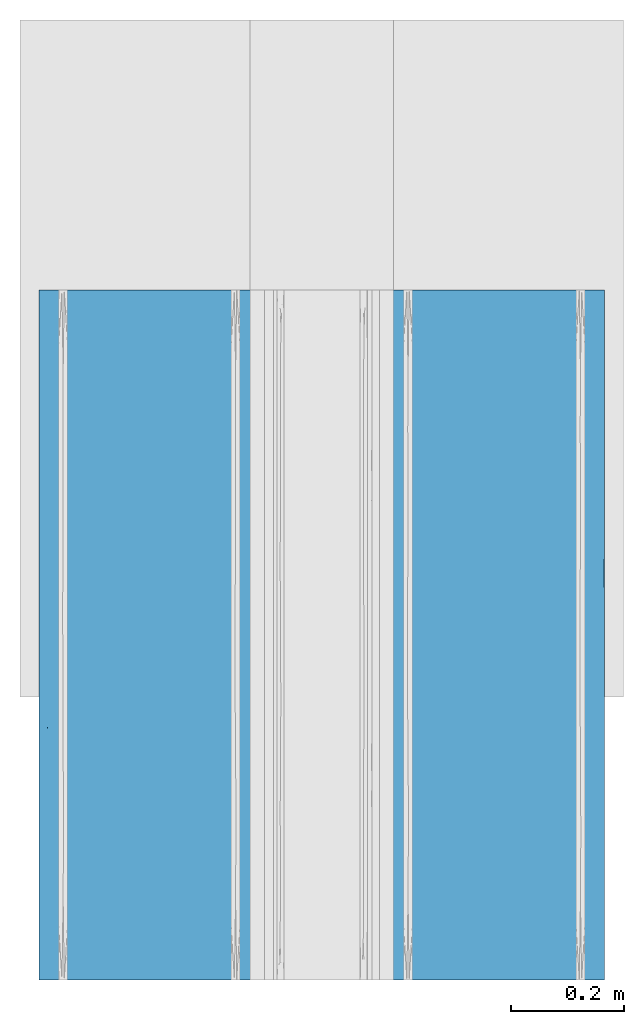
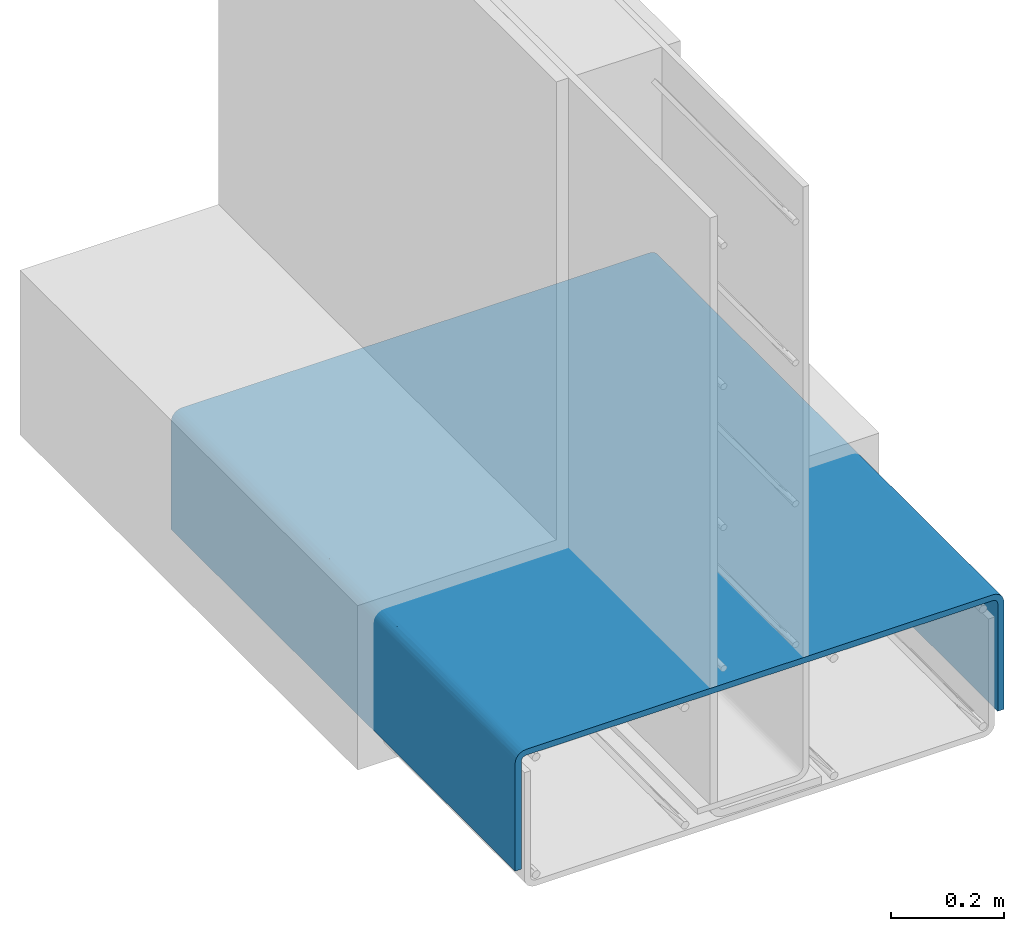
# One storey, part 3 of 10: 1 wall.
"""IFC2X3 building model written with IfcOpenShell, lengths in feet."""

from ifc_helpers import new_model, entity, si_unit, converted_unit, derived_unit, direction, frame, origin, place, context, subcontext, project, spatial, faceted_brep, material, type_object, element, save


model = new_model("IFC2X3")

# Units and contexts
model_context = context("Model", 3, precision=0.0001, world=origin(), true_north=direction((6.12303176911189e-17, 1.0)))
body_context = subcontext(model_context, "Body", "Model", "MODEL_VIEW")
ifc_project = project(units=[converted_unit("LENGTHUNIT", "FOOT", entity("IfcRatioMeasure", 0.3048), si_unit("LENGTHUNIT", "METRE"), dimensions=[1, 0, 0, 0, 0, 0, 0]), converted_unit("AREAUNIT", "SQUARE FOOT", entity("IfcRatioMeasure", 0.09290304), si_unit("AREAUNIT", "SQUARE_METRE"), dimensions=[2, 0, 0, 0, 0, 0, 0]), converted_unit("VOLUMEUNIT", "CUBIC FOOT", entity("IfcRatioMeasure", 0.028316846592), si_unit("VOLUMEUNIT", "CUBIC_METRE"), dimensions=[3, 0, 0, 0, 0, 0, 0]), converted_unit("PLANEANGLEUNIT", "DEGREE", entity("IfcRatioMeasure", 0.0174532925199433), si_unit("PLANEANGLEUNIT", "RADIAN"), dimensions=[0, 0, 0, 0, 0, 0, 0]), si_unit("MASSUNIT", "GRAM", prefix="KILO"), derived_unit("MASSDENSITYUNIT", [(si_unit("MASSUNIT", "GRAM", prefix="KILO"), 1), (si_unit("LENGTHUNIT", "METRE"), -3)]), si_unit("TIMEUNIT", "SECOND"), si_unit("FREQUENCYUNIT", "HERTZ"), si_unit("THERMODYNAMICTEMPERATUREUNIT", "DEGREE_CELSIUS"), derived_unit("THERMALTRANSMITTANCEUNIT", [(si_unit("MASSUNIT", "GRAM", prefix="KILO"), 1), (si_unit("THERMODYNAMICTEMPERATUREUNIT", "KELVIN"), -1), (si_unit("TIMEUNIT", "SECOND"), -3)]), derived_unit("VOLUMETRICFLOWRATEUNIT", [(si_unit("LENGTHUNIT", "METRE"), 3), (si_unit("TIMEUNIT", "SECOND"), -1)]), si_unit("ELECTRICCURRENTUNIT", "AMPERE"), si_unit("ELECTRICVOLTAGEUNIT", "VOLT"), si_unit("POWERUNIT", "WATT"), si_unit("FORCEUNIT", "NEWTON", prefix="KILO"), si_unit("ILLUMINANCEUNIT", "LUX"), si_unit("LUMINOUSFLUXUNIT", "LUMEN"), si_unit("LUMINOUSINTENSITYUNIT", "CANDELA"), derived_unit("USERDEFINED", [(si_unit("MASSUNIT", "GRAM", prefix="KILO"), -1), (si_unit("LENGTHUNIT", "METRE"), -2), (si_unit("TIMEUNIT", "SECOND"), 3), (si_unit("LUMINOUSFLUXUNIT", "LUMEN"), 1)]), derived_unit("LINEARVELOCITYUNIT", [(si_unit("LENGTHUNIT", "METRE"), 1), (si_unit("TIMEUNIT", "SECOND"), -1)]), si_unit("PRESSUREUNIT", "PASCAL"), derived_unit("USERDEFINED", [(si_unit("LENGTHUNIT", "METRE"), -2), (si_unit("MASSUNIT", "GRAM", prefix="KILO"), 1), (si_unit("TIMEUNIT", "SECOND"), -2)])], contexts=[model_context])

# Site, building, storey
site_placement = place(None, origin())
site = spatial("IfcSite", under=ifc_project, at=site_placement, CompositionType="ELEMENT")
building_placement = place(site_placement, origin())
building = spatial("IfcBuilding", under=site, at=building_placement, CompositionType="ELEMENT")
storey_placement = place(building_placement, frame((0.0, 0.0, 11.2604166666667)))
storey = spatial("IfcBuildingStorey", under=building, at=storey_placement, Name="2ND FLOOR", CompositionType="ELEMENT", Elevation=11.2604166666667)

# Wall
ifc_material = material()
wall_type = type_object("IfcWallType", Name="Generic Models 1", PredefinedType="NOTDEFINED", material=ifc_material)
wall_placement = place(storey_placement, frame((1428.03816369988, 0.24999999999582, 2.97795007741488), z_axis=(0.0, 0.0, 1.0), x_axis=(0.0, 1.0, 0.0)))
element("IfcWall", 1, at=wall_placement, inside=storey, type_object=wall_type, material=ifc_material, Name="Generic Models 46:Generic Models 1", ObjectType="Generic Models 46:Generic Models 1", context=body_context, shape_type="Brep", body=[
    faceted_brep([(4.0, 0.0, 0.0), (4.0, 0.0, 0.764315473946937), (4.0, -0.00252919618446867, 0.783526626268003), (4.0, -0.00994442419801089, 0.801428570306319), (4.0, -0.0217403485055456, 0.816801318160033), (4.0, -0.037113096359235, 0.828597242467586), (4.0, -0.0550150403976204, 0.8360124704811), (4.0, -0.0742261927186973, 0.838541666665574), (4.0, -3.20702380728176, 0.8385416666657), (4.0, -3.22623495960283, 0.8360124704811), (4.0, -3.24413690364122, 0.828597242467584), (4.0, -3.25950965149491, 0.816801318160033), (4.0, -3.27130557580244, 0.801428570306317), (4.0, -3.27872080381599, 0.783526626268003), (4.0, -3.28125000000045, 0.764315473946937), (4.0, -3.28125000000045, 0.0), (4.0, -3.23958333333371, 0.0), (4.0, -3.23958333333394, 0.764315473946937), (4.0, -3.2384738943872, 0.77274249938873), (4.0, -3.23522118397796, 0.780595236972985), (4.0, -3.23004686894546, 0.787338535610594), (4.0, -3.22330357030773, 0.792512850643233), (4.0, -3.21545083272349, 0.795765561052388), (4.0, -3.20702380728176, 0.796875000000808), (4.0, -0.0742261927186973, 0.796874999999034), (4.0, -0.065799167276964, 0.795765561052388), (4.0, -0.0579464296927199, 0.792512850643233), (4.0, -0.0512031310549901, 0.787338535610594), (4.0, -0.0460288160224991, 0.780595236972985), (4.0, -0.0427761056132567, 0.77274249938873), (4.0, -0.0416666666667425, 0.764315473946937), (4.0, -0.0416666666667425, 0.0), (0.0, -0.0550150403976204, 0.836012470481107), (0.0, -0.037113096359235, 0.828597242467593), (0.0, -0.0217403485055456, 0.81680131816004), (0.0, -0.00994442419801089, 0.801428570306326), (0.0, -0.00252919618446867, 0.78352662626801), (0.0, 0.0, 0.764315473946944), (0.0, 0.0, 0.0), (0.0, -0.0416666666667425, 0.0), (0.0, -0.0416666666665151, 0.764315473946944), (0.0, -0.0427761056132567, 0.772742499388738), (0.0, -0.0460288160224991, 0.780595236972992), (0.0, -0.0512031310549901, 0.787338535610601), (0.0, -0.0579464296927199, 0.79251285064324), (0.0, -0.065799167276964, 0.795765561052395), (0.0, -0.0742261927186973, 0.796874999999041), (0.0, -3.20702380728176, 0.796874999999041), (0.0, -3.21545083272349, 0.795765561052395), (0.0, -3.22330357030773, 0.79251285064324), (0.0, -3.23004686894546, 0.787338535610601), (0.0, -3.23522118397796, 0.780595236972992), (0.0, -3.2384738943872, 0.772742499388738), (0.0, -3.23958333333394, 0.764315473946944), (0.0, -3.23958333333371, 0.0), (0.0, -3.28125000000045, 0.0), (0.0, -3.28125000000045, 0.764315473946944), (0.0, -3.27872080381599, 0.78352662626801), (0.0, -3.27130557580244, 0.801428570306324), (0.0, -3.25950965149491, 0.81680131816004), (0.0, -3.24413690364122, 0.828597242467591), (0.0, -3.22623495960283, 0.836012470481107), (0.0, -3.20702380728176, 0.838541666665707), (0.0, -0.0742261927186973, 0.838541666665707), (0.180442580674759, -0.0742261927186973, 0.796874999999041), (0.360885161349518, -0.0742261927186973, 0.796874999999041), (0.639114829065253, -0.0742261927186973, 0.796874999999041), (0.958672224427413, -0.0742261927186973, 0.796874999999039), (1.2782296581305, -0.0742261927186973, 0.796874999999037), (1.5977870918336, -0.0742261927186973, 0.796874999999037), (1.75756578951468, -0.0742261927186973, 0.796874999999037), (1.91734448719576, -0.0742261927186973, 0.796874999999037), (2.23690188255792, -0.0742261927189247, 0.796874999999037), (2.55645931626101, -0.0742261927186973, 0.796874999999037), (2.73690189693576, -0.0742261927186973, 0.796874999999037), (2.91734451595145, -0.0742261927186973, 0.796874999999037), (3.09778709662621, -0.0742261927186973, 0.796874999999035), (3.27822967730097, -0.0742261927186973, 0.796874999999035), (3.45867225797573, -0.0742261927186973, 0.796874999999034), (3.63911483865049, -0.0742261927186973, 0.796874999999034), (3.81955741932524, -0.0742261927189247, 0.796874999999034), (3.81955740038469, -3.20702380728176, 0.796874999999034), (3.63911480076936, -3.20702380728176, 0.796874999999035), (3.36088523640947, -3.20702380728176, 0.796874999999034), (3.04132770589896, -3.20702380728176, 0.796874999999035), (2.72177032410369, -3.20702380728176, 0.796874999999035), (2.40221294230842, -3.20702380728176, 0.796874999999035), (2.24243417705317, -3.20702380728176, 0.796874999999037), (2.08265541179791, -3.20702380728176, 0.796874999999037), (1.76309803000264, -3.20702380728176, 0.796874999999039), (1.44354064820737, -3.20702380728198, 0.796874999999039), (1.26309804859205, -3.20702380728198, 0.796874999999041), (1.08265544897672, -3.20702380728198, 0.796874999999039), (0.902212849361396, -3.20702380728176, 0.796874999999039), (0.721770249746071, -3.20702380728176, 0.796874999999039), (0.541327650130745, -3.20702380728176, 0.796874999999039), (0.360885050515419, -3.20702380728176, 0.796874999999039), (0.180442599615337, -3.20702380728176, 0.796874999999041), (0.544897213082494, -3.20702380728176, 0.838541666665705), (1.08978317725471, -3.20702380728176, 0.838541666665705), (1.63466914142694, -3.20702380728176, 0.838541666665705), (2.17956635450942, -3.20702380728176, 0.838541666665703), (2.91022807165557, -3.20702380728176, 0.838541666665702), (3.45511403582779, -3.20702380728176, 0.8385416666657), (3.45510810898161, -0.0742261927186973, 0.838541666665702), (2.91022025791022, -0.07422619271847, 0.838541666665702), (2.36533240683882, -0.0742261927186973, 0.838541666665703), (1.82044051582043, -0.0742261927189247, 0.838541666665705), (1.08977974208979, -0.0742261927186973, 0.838541666665707), (0.544891891018391, -0.0742261927186973, 0.838541666665705), (0.270663875967365, -3.23004686892386, 0.787338535632113), (1.67602113862125, -3.22975703857628, 0.787624762474263), (1.37499998954591, -3.23148950117525, 0.785799248267155), (0.18044259048145, -3.23958333333394, 0.764315473946944), (0.469298945513915, -3.2285244338259, 0.788766359308221), (3.81955740951857, -3.23958333333394, 0.764315473946937), (1.24999995979229, -3.23958333333394, 0.764315473946942), (1.17539910940274, -3.22962860994699, 0.787749330505351), (1.74999998659744, -3.23958333333394, 0.76431547394694), (1.87499998597026, -3.23046662737761, 0.786910980639316), (2.0, -3.23958333333394, 0.76431547394694), (0.99999994638972, -3.23958333333394, 0.764315473946942), (2.63911487264742, -3.23958333333394, 0.76431547394694), (2.62746326313055, -3.22882052529053, 0.788502780964922), (2.82017627891887, -3.2313064529244, 0.786005929390056), (3.72933611259509, -3.2300468696244, 0.787338534931672), (3.03856157748761, -3.23090061075959, 0.78645189173349), (0.499999919584574, -3.23958333333394, 0.764315473946944), (0.639296465193045, -3.23376190743579, 0.782894944792119), (0.749999932987147, -3.23958333333394, 0.764315473946944), (3.50074415373243, -3.23004686991999, 0.78733853463595), (3.45867222855569, -3.23958333333394, 0.764315473946937), (3.31407359807177, -3.22992275871388, 0.787461980379685), (3.63911481903713, -3.23958333333394, 0.764315473946938), (2.31955743632372, -3.23958333333394, 0.76431547394694), (2.06289507835155, -3.23052849705073, 0.786846614521622), (2.32232355337972, -3.22916022485538, 0.788192277622201), (0.99377865387029, -3.22770490285666, 0.789463337127676), (0.81199162741404, -3.22945275282632, 0.787917701352265), (2.95867230897113, -3.23958333333394, 0.76431547394694), (1.49999997319487, -3.23958333333394, 0.76431547394694), (3.27822963807425, -3.23958333333394, 0.764315473946938), (3.1184509199124, -3.23958333333371, 0.764315473946938), (3.45510681687277, -3.28125000000045, 0.764315473946937), (2.9102205524969, -3.28125000000045, 0.764315473946938), (2.36533428812103, -3.28125000000045, 0.764315473946938), (1.82044110499379, -3.28125000000045, 0.76431547394694), (1.08977944750312, -3.28125000000045, 0.76431547394694), (0.544886264375879, -3.28125000000045, 0.764315473946944), (3.52166542093068, -3.27307272984172, 0.798183859119488), (3.16735852497803, -3.27559986750953, 0.792720608151132), (3.55697232224895, -3.27814806918377, 0.785549104216075), (3.44244832502729, -3.26591140521077, 0.809501517098296), (2.30981632376839, -3.2214522514189, 0.83712582819207), (2.10986574916034, -3.23430911441324, 0.833344740930324), (2.54488968757733, -3.23376488518807, 0.833557386383943), (2.99234246870892, -3.234844018893, 0.833130904712389), (3.18266546808837, -3.22134943712786, 0.837146126937531), (2.74782005596116, -3.22094485864091, 0.837224540698461), (3.62777765216729, -3.25220985042984, 0.823203071878501), (0.557551674661685, -3.2522098504171, 0.823203071888189), (0.83264147428799, -3.23542894146067, 0.832891534185215), (0.478334578422369, -3.24089219243842, 0.830364396515025), (3.18266546786375, -3.28010648361737, 0.777294306912523), (0.489688549779709, -3.26591140520213, 0.809501517109624), (1.22348175499143, -3.26591140518804, 0.809501517127977), (3.16200306403063, -3.25220985042893, 0.823203071879215), (1.7751109563393, -3.27034247763982, 0.803048840307342), (2.47859294360805, -3.26591140521055, 0.809501517098518), (1.85103734978417, -3.25737077455096, 0.81885638127639), (1.45511031216032, -3.27762254186518, 0.787235909386755), (2.762930708851, -3.27254841785361, 0.799187426787592), (2.23413872796361, -3.27774239132714, 0.78686341301351), (2.73095051624819, -3.27841277700213, 0.784641385679819), (0.707855703554059, -3.27559986750089, 0.792720608171935), (0.392495590752652, -3.27997643130993, 0.778006432019362), (2.96052063433173, -3.263822709745, 0.81210053818781), (0.443027677394535, -3.22825743753151, 0.835439735854816), (3.60739017738584, -3.2207185562861, 0.837267386432035), (1.16662977149587, -3.25086713986525, 0.824209462572654), (0.817334531552509, -3.22000264022608, 0.837398150286299), (1.29274499419331, -3.22197361687381, 0.837020569220137), (1.84145037526764, -3.279638335546, 0.779699165651849), (3.44067317160746, -3.2354289414809, 0.832891534176856), (0.817334532369758, -3.28006364925386, 0.777533233598342), (1.06530183645968, -3.27748746686962, 0.787647862658766), (2.7417926689386, -3.25473179382448, 0.821179132865023), (1.68555575695714, -3.23113803312845, 0.834515415523375), (1.27517456621122, -3.2366291876881, 0.832381979193816), (2.34763943584665, -3.24998374636402, 0.824846220841172), (1.80883755227711, -3.24484309206287, 0.828184319123409), (3.52166542074625, -0.0403578075447513, 0.830364396506107), (3.16735852451758, -0.0458210585120469, 0.832891534173749), (3.55697232197402, -0.0529925624489351, 0.835439735848835), (3.4424483247242, -0.0290401495658443, 0.823203071874831), (2.30981632325289, -0.00141583847516813, 0.778743918092054), (2.10986574904963, -0.00519692574175679, 0.791600781094628), (2.54488968762939, -0.00498428027958653, 0.791056551847522), (2.99234246861257, -0.0054107619498609, 0.792135685549805), (3.18266546767638, -0.00139553972780959, 0.778641103791426), (2.74782005556499, -0.00131712596567013, 0.778236525297695), (3.62777765200877, -0.015338594786499, 0.809501517094001), (0.557551674741563, -0.0153385947714924, 0.80950151707456), (0.832641474299401, -0.00565013247546631, 0.792720608114053), (0.478334578241977, -0.0081772701466889, 0.798183859095692), (3.18266546729613, -0.0612473597489043, 0.837398150281812), (0.48968854990307, -0.0290401495483366, 0.8232030718613), (1.22348175454259, -0.0290401495192327, 0.823203071838968), (3.16200306365112, -0.0153385947853621, 0.809501517092484), (1.77511095543671, -0.0354928263348029, 0.827634144290686), (2.47859294286626, -0.029040149565617, 0.823203071874545), (1.8510373494731, -0.0196852853869132, 0.814662441213665), (1.45511031190418, -0.0513057572495654, 0.83491420852082), (2.76293070826903, -0.0393542398726368, 0.829840084516004), (2.234138728278, -0.0516782536694791, 0.835034057997794), (2.7309505162361, -0.053900280979633, 0.835704443665625), (0.707855703412768, -0.0458210584790777, 0.832891534160074), (0.392495591046848, -0.0605352346387917, 0.83726809797362), (2.96052063381764, -0.0264411284733796, 0.821114376406308), (0.443027677445541, -0.00310193080781573, 0.785549104186204), (3.45511494242228, 0.0, 0.764315473946937), (3.60739017718949, -0.0012742802334742, 0.778010222949979), (1.16662977173338, -0.0143322040798921, 0.80815880651239), (1.08977752422302, 0.0, 0.76431547394694), (0.817334531745283, -0.00114351637785148, 0.777294306883148), (1.29274499421645, -0.00152109744340123, 0.779265283528547), (1.84145037480216, -0.0588425010055289, 0.836930002209542), (3.44067317135564, -0.00565013248819923, 0.792720608144727), (2.17955504844604, 0.0, 0.76431547394694), (0.817334532997676, -0.0610084330523932, 0.837355315916428), (1.06530183630386, -0.0508938039752138, 0.834779133524355), (2.74179266914029, -0.0173625338056809, 0.812023460495732), (0.544892466645305, 0.0, 0.764315473946944), (1.68555575699555, -0.00402625113338217, 0.788429699767551), (1.63466258180074, 0.0, 0.76431547394694), (2.91022247577698, 0.0, 0.764315473946937), (1.27517456629524, -0.00615968746637918, 0.793920854340866), (2.34763943656028, -0.0136954458341734, 0.807275413042973), (1.80883755086076, -0.0103573475389567, 0.802134758722298), (3.81955741461876, -0.0416666666665151, 0.764315473946937), (3.5, -0.0416666666665151, 0.764315473946937), (3.25, -0.0416666666665151, 0.764315473946938), (3.0, -0.0416666666665151, 0.764315473946937), (2.75, -0.0416666666665151, 0.764315473946938), (2.5, -0.0416666666665151, 0.76431547394694), (2.25, -0.0416666666665151, 0.76431547394694), (2.0, -0.0416666666665151, 0.76431547394694), (1.68044258538124, -0.0416666666665151, 0.76431547394694), (1.36088517076249, -0.0416666666665151, 0.76431547394694), (1.04132775614373, -0.0416666666665151, 0.764315473946942), (0.881549048834349, -0.0416666666667425, 0.764315473946944), (0.72177034152497, -0.0416666666665151, 0.764315473946944), (0.541327756143728, -0.0416666666665151, 0.764315473946942), (0.360885170762486, -0.0416666666665151, 0.764315473946942), (0.180442585381244, -0.0416666666665151, 0.764315473946944), (0.270663875434872, -0.051203131045213, 0.787338535600716), (0.961438393850556, -0.0503493892540519, 0.786451891747655), (1.17982369128813, -0.0499435468639149, 0.786005929152486), (0.499255821607445, -0.0512031310479415, 0.787338535603515), (3.72933612501895, -0.0512031316836783, 0.787338536239217), (2.62499997689097, -0.0497604985807811, 0.785799247989004), (2.82460085350215, -0.0516213900368712, 0.78774933048944), (2.12499998122799, -0.0507833723324893, 0.786910980338181), (3.36070350408131, -0.0474880927536105, 0.782894945064179), (0.685926374043803, -0.0513272416494601, 0.787461980738787), (3.00622131095971, -0.0535450963159292, 0.789463336446891), (3.18800833916986, -0.0517972471454868, 0.787917701325156), (2.32397882494683, -0.0514929611706521, 0.787624762227036), (3.53070102933502, -0.0527255665924713, 0.788766359675604), (1.37253670766125, -0.0524294745946463, 0.788502780861105), (1.93710489044044, -0.0507215027123493, 0.786846614273992), (1.67767641270328, -0.0520897748690459, 0.78819227736631)], [[[0, 1, 2, 3, 4, 5, 6, 7, 8, 9, 10, 11, 12, 13, 14, 15, 16, 17, 18, 19, 20, 21, 22, 23, 24, 25, 26, 27, 28, 29, 30, 31]], [[32, 33, 34, 35, 36, 37, 38, 39, 40, 41, 42, 43, 44, 45, 46, 47, 48, 49, 50, 51, 52, 53, 54, 55, 56, 57, 58, 59, 60, 61, 62, 63]], [[47, 46, 64, 65, 66, 67, 68, 69, 70, 71, 72, 73, 74, 75, 76, 77, 78, 79, 80, 24, 23, 81, 82, 83, 84, 85, 86, 87, 88, 89, 90, 91, 92, 93, 94, 95, 96, 97]], [[62, 98, 99, 100, 101, 102, 103, 8, 7, 104, 105, 106, 107, 108, 109, 63]], [[96, 110, 97]], [[90, 111, 112]], [[51, 113, 52]], [[110, 96, 114]], [[113, 53, 52]], [[17, 115, 18]], [[48, 97, 49]], [[112, 116, 117]], [[118, 119, 120]], [[117, 116, 121]], [[122, 123, 124]], [[47, 97, 48]], [[19, 125, 20]], [[50, 110, 51]], [[126, 124, 84]], [[22, 21, 81]], [[113, 51, 110]], [[21, 125, 81]], [[127, 128, 129]], [[130, 131, 132]], [[20, 125, 21]], [[49, 110, 50]], [[130, 125, 133]], [[134, 135, 136]], [[137, 138, 93]], [[82, 81, 125]], [[119, 89, 88]], [[18, 115, 19]], [[49, 97, 110]], [[81, 23, 22]], [[115, 125, 19]], [[110, 127, 113]], [[127, 110, 114]], [[82, 125, 130]], [[133, 125, 115]], [[130, 83, 82]], [[132, 83, 130]], [[128, 138, 129]], [[114, 95, 128]], [[126, 139, 124]], [[112, 140, 116]], [[121, 137, 117]], [[84, 132, 126]], [[88, 135, 119]], [[122, 134, 123]], [[128, 95, 94]], [[93, 138, 94]], [[129, 138, 121]], [[138, 128, 94]], [[114, 96, 95]], [[114, 128, 127]], [[132, 84, 83]], [[141, 142, 132, 131]], [[142, 126, 132]], [[126, 142, 139]], [[85, 84, 124]], [[85, 124, 123]], [[124, 139, 122]], [[123, 86, 85]], [[136, 86, 123]], [[119, 118, 111]], [[135, 120, 119]], [[89, 119, 111]], [[89, 111, 90]], [[111, 118, 140]], [[135, 134, 120]], [[88, 87, 135]], [[87, 136, 135]], [[136, 87, 86]], [[134, 136, 123]], [[130, 133, 131]], [[140, 112, 111]], [[117, 91, 112]], [[92, 137, 93]], [[137, 92, 117]], [[90, 112, 91]], [[117, 92, 91]], [[138, 137, 121]], [[54, 53, 113, 127, 129, 121, 116, 140, 118, 120, 134, 122, 139, 142, 141, 131, 133, 115, 17, 16]], [[55, 54, 16, 15]], [[39, 38, 0, 31]], [[55, 15, 14, 143, 144, 145, 146, 147, 148, 56]], [[149, 150, 151]], [[152, 12, 11]], [[153, 154, 155]], [[156, 157, 158]], [[11, 10, 159]], [[150, 149, 152]], [[160, 161, 162]], [[143, 163, 144]], [[164, 165, 160]], [[152, 159, 166]], [[167, 168, 169]], [[170, 147, 146]], [[171, 172, 173]], [[57, 174, 58]], [[56, 148, 175]], [[163, 151, 150]], [[176, 171, 150]], [[177, 162, 161]], [[165, 167, 169]], [[8, 103, 178]], [[165, 169, 179]], [[164, 160, 59]], [[99, 180, 181]], [[170, 146, 182]], [[183, 166, 159]], [[160, 60, 59]], [[180, 177, 161]], [[183, 10, 9]], [[101, 153, 158]], [[148, 184, 175]], [[174, 184, 185]], [[155, 158, 153]], [[186, 156, 155]], [[59, 58, 164]], [[179, 160, 165]], [[159, 152, 11]], [[171, 176, 168]], [[103, 157, 178]], [[156, 183, 157]], [[98, 180, 99]], [[62, 61, 177]], [[14, 13, 151]], [[147, 184, 148]], [[185, 165, 174]], [[182, 146, 145]], [[144, 163, 173]], [[58, 174, 164]], [[165, 164, 174]], [[187, 100, 181]], [[102, 157, 103]], [[179, 161, 160]], [[170, 167, 165]], [[181, 188, 187]], [[154, 189, 155]], [[179, 169, 190]], [[158, 157, 102]], [[178, 183, 9]], [[186, 155, 189]], [[166, 183, 156]], [[101, 158, 102]], [[156, 158, 155]], [[98, 177, 180]], [[154, 153, 187]], [[187, 190, 154]], [[154, 190, 189]], [[169, 168, 189]], [[168, 176, 186]], [[190, 187, 188]], [[189, 190, 169]], [[185, 147, 170]], [[175, 174, 57]], [[174, 175, 184]], [[56, 175, 57]], [[183, 178, 157]], [[8, 178, 9]], [[98, 62, 177]], [[161, 188, 181]], [[161, 181, 180]], [[101, 100, 153]], [[187, 153, 100]], [[100, 99, 181]], [[60, 177, 61]], [[161, 179, 188]], [[190, 188, 179]], [[177, 60, 162]], [[60, 160, 162]], [[143, 14, 151]], [[173, 163, 150]], [[171, 173, 150]], [[172, 145, 173]], [[143, 151, 163]], [[12, 151, 13]], [[176, 150, 152]], [[172, 171, 168]], [[152, 166, 176]], [[186, 176, 166]], [[151, 12, 149]], [[12, 152, 149]], [[156, 186, 166]], [[168, 186, 189]], [[183, 159, 10]], [[147, 185, 184]], [[165, 185, 170]], [[182, 167, 170]], [[168, 167, 172]], [[144, 173, 145]], [[167, 182, 172]], [[182, 145, 172]], [[191, 192, 193]], [[194, 5, 4]], [[195, 196, 197]], [[198, 199, 200]], [[4, 3, 201]], [[192, 191, 194]], [[202, 203, 204]], [[104, 205, 105]], [[206, 207, 202]], [[194, 201, 208]], [[209, 210, 211]], [[212, 108, 107]], [[213, 214, 215]], [[32, 216, 33]], [[63, 109, 217]], [[205, 193, 192]], [[218, 213, 192]], [[219, 204, 203]], [[207, 209, 211]], [[1, 220, 221]], [[207, 211, 222]], [[206, 202, 34]], [[223, 224, 225]], [[212, 107, 226]], [[227, 208, 201]], [[202, 35, 34]], [[224, 219, 203]], [[227, 3, 2]], [[228, 195, 200]], [[109, 229, 217]], [[216, 229, 230]], [[197, 200, 195]], [[231, 198, 197]], [[34, 33, 206]], [[222, 202, 207]], [[201, 194, 4]], [[213, 218, 210]], [[220, 199, 221]], [[198, 227, 199]], [[232, 224, 223]], [[37, 36, 219]], [[7, 6, 193]], [[108, 229, 109]], [[230, 207, 216]], [[226, 107, 106]], [[105, 205, 215]], [[33, 216, 206]], [[207, 206, 216]], [[233, 234, 225]], [[235, 199, 220]], [[222, 203, 202]], [[212, 209, 207]], [[225, 236, 233]], [[196, 237, 197]], [[222, 211, 238]], [[200, 199, 235]], [[221, 227, 2]], [[231, 197, 237]], [[208, 227, 198]], [[228, 200, 235]], [[198, 200, 197]], [[232, 219, 224]], [[196, 195, 233]], [[233, 238, 196]], [[196, 238, 237]], [[211, 210, 237]], [[210, 218, 231]], [[238, 233, 236]], [[237, 238, 211]], [[230, 108, 212]], [[217, 216, 32]], [[216, 217, 229]], [[63, 217, 32]], [[227, 221, 199]], [[1, 221, 2]], [[232, 37, 219]], [[203, 236, 225]], [[203, 225, 224]], [[228, 234, 195]], [[233, 195, 234]], [[234, 223, 225]], [[35, 219, 36]], [[203, 222, 236]], [[238, 236, 222]], [[219, 35, 204]], [[35, 202, 204]], [[104, 7, 193]], [[215, 205, 192]], [[213, 215, 192]], [[214, 106, 215]], [[104, 193, 205]], [[5, 193, 6]], [[218, 192, 194]], [[214, 213, 210]], [[194, 208, 218]], [[231, 218, 208]], [[193, 5, 191]], [[5, 194, 191]], [[198, 231, 208]], [[210, 231, 237]], [[227, 201, 3]], [[108, 230, 229]], [[207, 230, 212]], [[226, 209, 212]], [[210, 209, 214]], [[105, 215, 106]], [[209, 226, 214]], [[226, 106, 214]], [[38, 37, 232, 223, 234, 228, 235, 220, 1, 0]], [[40, 39, 31, 30, 239, 240, 241, 242, 243, 244, 245, 246, 247, 248, 249, 250, 251, 252, 253, 254]], [[44, 255, 64]], [[256, 257, 67]], [[255, 254, 253, 252, 258]], [[239, 28, 259]], [[260, 243, 261]], [[245, 262, 246]], [[28, 239, 29]], [[263, 241, 240]], [[41, 254, 42]], [[239, 30, 29]], [[254, 41, 40]], [[258, 252, 264]], [[265, 266, 76]], [[45, 44, 64]], [[25, 80, 26]], [[261, 243, 242]], [[260, 73, 267]], [[25, 24, 80]], [[64, 46, 45]], [[262, 72, 71]], [[268, 240, 259]], [[259, 79, 268]], [[248, 269, 257]], [[258, 66, 65, 64, 255]], [[247, 270, 271]], [[42, 255, 43]], [[27, 259, 28]], [[26, 259, 27]], [[43, 255, 44]], [[259, 80, 79]], [[26, 80, 259]], [[239, 259, 240]], [[42, 254, 255]], [[264, 66, 258]], [[263, 266, 241]], [[268, 78, 263]], [[256, 249, 257]], [[260, 244, 243]], [[242, 265, 261]], [[67, 264, 256]], [[71, 270, 262]], [[248, 247, 269]], [[263, 78, 77]], [[76, 266, 77]], [[241, 266, 242]], [[266, 263, 77]], [[268, 79, 78]], [[268, 263, 240]], [[264, 67, 66]], [[251, 250, 264, 252]], [[250, 256, 264]], [[256, 250, 249]], [[68, 67, 257]], [[68, 257, 269]], [[257, 249, 248]], [[269, 69, 68]], [[271, 69, 269]], [[262, 245, 267]], [[270, 246, 262]], [[72, 262, 267]], [[72, 267, 73]], [[267, 245, 244]], [[270, 247, 246]], [[71, 70, 270]], [[70, 271, 270]], [[271, 70, 69]], [[247, 271, 269]], [[244, 260, 267]], [[261, 74, 260]], [[75, 265, 76]], [[265, 75, 261]], [[73, 260, 74]], [[261, 75, 74]], [[266, 265, 242]]]),
])

save(model, "model.ifc")
